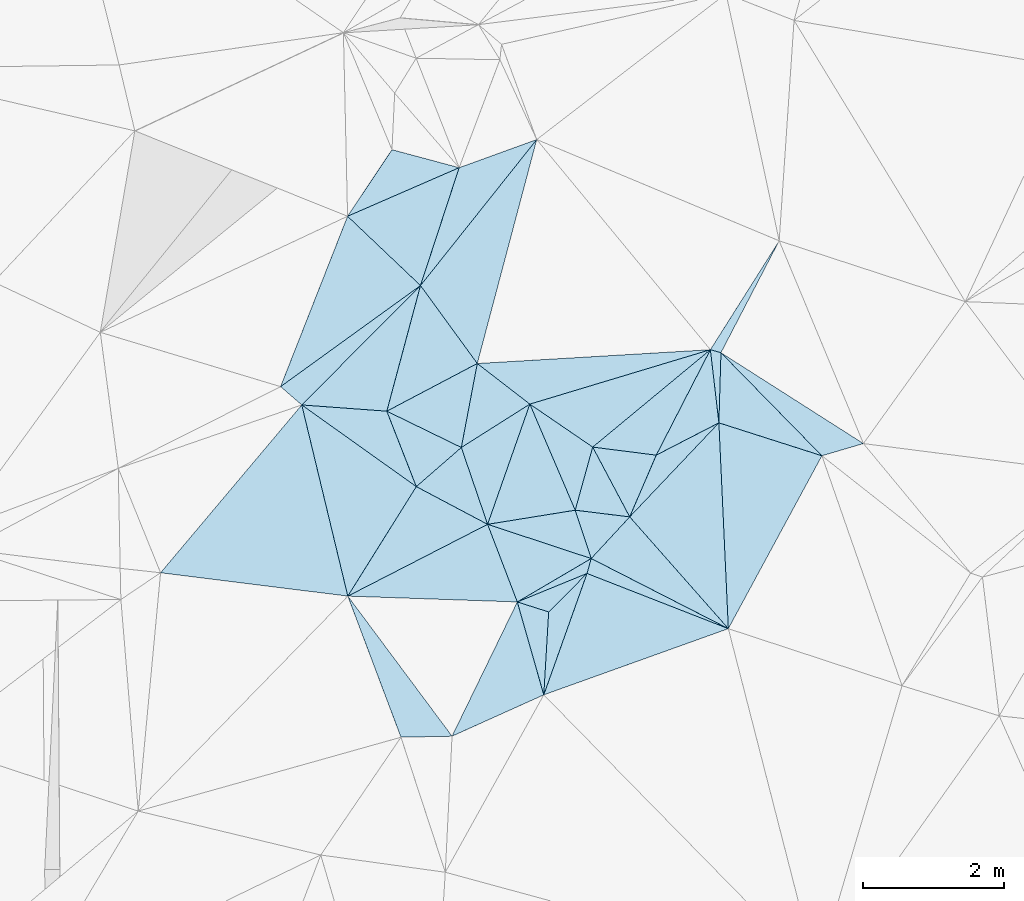
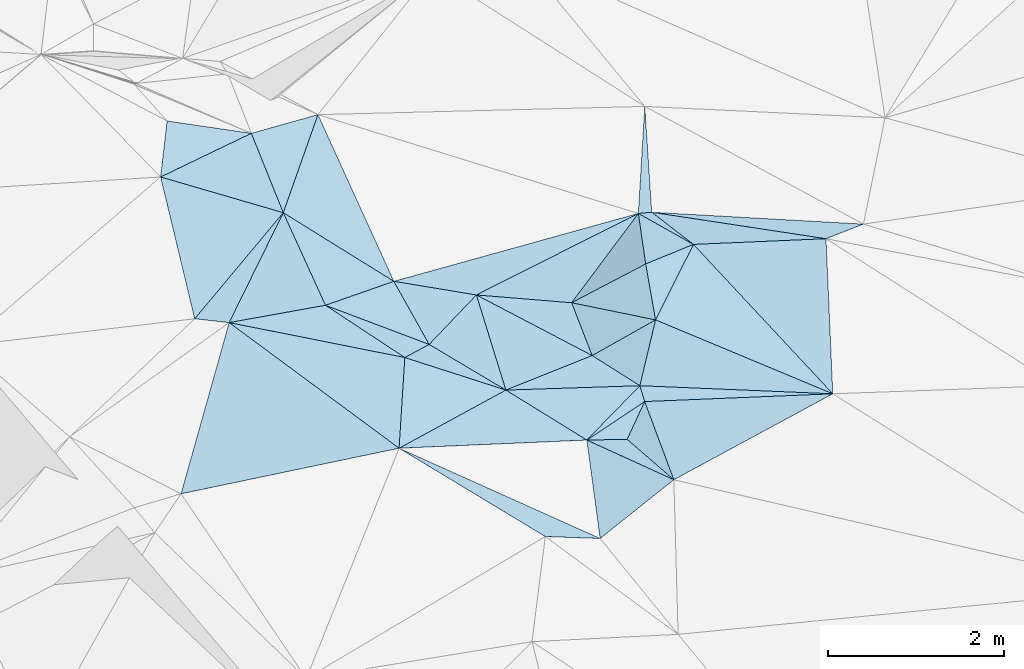
# One storey, part 156 of 275: 45 plates.
"""IFC2X3 building model written with IfcOpenShell, lengths in millimetres."""

from ifc_helpers import new_model, si_unit, frame, origin_with_axes, place, context, subcontext, project, spatial, polyline, outline, extrude, material, type_object, element, save


model = new_model("IFC2X3")

# Units and contexts
model_context = context("Model", 3, precision=1e-05, world=origin_with_axes())
body_context = subcontext(model_context, "Body", "Model", "MODEL_VIEW")
ifc_project = project(units=[si_unit("LENGTHUNIT", "METRE", prefix="MILLI"), si_unit("AREAUNIT", "SQUARE_METRE"), si_unit("VOLUMEUNIT", "CUBIC_METRE"), si_unit("MASSUNIT", "GRAM", prefix="KILO"), si_unit("TIMEUNIT", "SECOND"), si_unit("PLANEANGLEUNIT", "RADIAN"), si_unit("SOLIDANGLEUNIT", "STERADIAN"), si_unit("THERMODYNAMICTEMPERATUREUNIT", "DEGREE_CELSIUS"), si_unit("LUMINOUSINTENSITYUNIT", "LUMEN")], contexts=[model_context])

# Site, building, storey
site_placement = place(None, origin_with_axes())
site = spatial("IfcSite", under=ifc_project, at=site_placement, CompositionType="ELEMENT")
building_placement = place(site_placement, origin_with_axes())
building = spatial("IfcBuilding", under=site, at=building_placement, Name="Undefined", CompositionType="ELEMENT")
storey_placement = place(building_placement, origin_with_axes())
storey = spatial("IfcBuildingStorey", under=building, at=storey_placement, Name="Undefined", CompositionType="ELEMENT", Elevation=0.0)

# Plates
ifc_material = material()
plate_type_1 = type_object("IfcPlateType", PredefinedType="NOTDEFINED")
plate_1_placement = place(storey_placement, frame((-36324.0529379722, 116391.682802069, 45879.5042539643), z_axis=(-0.0657141059388461, 0.112214905189025, -0.991508684447129), x_axis=(-0.0455778950817998, 0.992281826204322, 0.115323167076387)))
element("IfcPlate", 1, at=plate_1_placement, inside=storey, type_object=plate_type_1, material=ifc_material, Name="00", context=body_context, shape_type="SweptSolid", body=[
    extrude(outline(polyline([(0.0, 0.0), (2948.23681640625, -1.5352270565927e-09), (2399.90893554688, 1443.86169433594), (0.0, 0.0)])), frame((-8.85201319254618e-08, 2.18876761149539e-07, -0.5000001331573), z_axis=(0.0, 0.0, 1.0), x_axis=(1.0, 0.0, 0.0)), (0.0, 0.0, 1.0), 1.0),
])
plate_type_2 = type_object("IfcPlateType", PredefinedType="NOTDEFINED")
plate_2_placement = place(storey_placement, frame((-36429.0984635988, 120314.041744215, 46049.5124536224), z_axis=(-0.151597191690274, -0.161799097690605, -0.975109913526741), x_axis=(0.69970543931873, -0.714364877257852, 0.00975296509565245)))
element("IfcPlate", 2, at=plate_2_placement, inside=storey, type_object=plate_type_2, material=ifc_material, Name="00", context=body_context, shape_type="SweptSolid", body=[
    extrude(outline(polyline([(0.0, 0.0), (2050.65844726563, 3.08500602841377e-09), (693.338256835938, 736.940979003906), (0.0, 0.0)])), frame((-8.85201319254618e-08, 2.18876761149539e-07, -0.5000001331573), z_axis=(0.0, 0.0, 1.0), x_axis=(1.0, 0.0, 0.0)), (0.0, 0.0, 1.0), 1.0),
])
plate_type_3 = type_object("IfcPlateType", PredefinedType="NOTDEFINED")
plate_3_placement = place(storey_placement, frame((-36323.9551393121, 116391.839074783, 45879.552046232), z_axis=(0.129888435724304, 0.424791822155536, -0.895924607372112), x_axis=(-0.8870264109226, 0.453553524861327, 0.0864485188516094)))
element("IfcPlate", 3, at=plate_3_placement, inside=storey, type_object=plate_type_3, material=ifc_material, Name="00", context=body_context, shape_type="SweptSolid", body=[
    extrude(outline(polyline([(0.0, 0.0), (2197.83984375, -7.27595761418343e-11), (2011.83898925781, 863.135986328125), (0.0, 0.0)])), frame((-8.85201319254618e-08, 2.18876761149539e-07, -0.5000001331573), z_axis=(0.0, 0.0, 1.0), x_axis=(1.0, 0.0, 0.0)), (0.0, 0.0, 1.0), 1.0),
])
plate_type_4 = type_object("IfcPlateType", PredefinedType="NOTDEFINED")
plate_4_placement = place(storey_placement, frame((-38273.5949539669, 117388.528462846, 46069.5051526097), z_axis=(-0.0654767039366603, 0.127412382830634, -0.989686256317128), x_axis=(-0.86204342690481, -0.506767930713714, -0.00820941717492133)))
element("IfcPlate", 4, at=plate_4_placement, inside=storey, type_object=plate_type_4, material=ifc_material, Name="00", context=body_context, shape_type="SweptSolid", body=[
    extrude(outline(polyline([(0.0, 0.0), (1218.11328125, 3.27418092638254e-09), (1021.49774169922, 1177.38793945313), (0.0, 0.0)])), frame((-8.85201319254618e-08, 2.18876761149539e-07, -0.5000001331573), z_axis=(0.0, 0.0, 1.0), x_axis=(1.0, 0.0, 0.0)), (0.0, 0.0, 1.0), 1.0),
])
plate_type_5 = type_object("IfcPlateType", PredefinedType="NOTDEFINED")
plate_5_placement = place(storey_placement, frame((-39145.5367006344, 119583.364981642, 46299.5028179796), z_axis=(-0.076772100434279, 0.0728998339284036, -0.994380037414328), x_axis=(-0.844680873789874, -0.534637469978889, 0.0260191688596494)))
element("IfcPlate", 5, at=plate_5_placement, inside=storey, type_object=plate_type_5, material=ifc_material, Name="00", context=body_context, shape_type="SweptSolid", body=[
    extrude(outline(polyline([(0.0, 0.0), (1152.99609375, 5.96628524363041e-09), (325.152893066406, 892.006530761719), (0.0, 0.0)])), frame((-8.85201319254618e-08, 2.18876761149539e-07, -0.5000001331573), z_axis=(0.0, 0.0, 1.0), x_axis=(1.0, 0.0, 0.0)), (0.0, 0.0, 1.0), 1.0),
])
plate_type_6 = type_object("IfcPlateType", PredefinedType="NOTDEFINED")
plate_6_placement = place(storey_placement, frame((-40759.204701639, 118410.805984725, 46709.5090750769), z_axis=(-0.0934703041772777, 0.164942871516741, -0.981864120626077), x_axis=(-0.80211392311818, 0.571742619947235, 0.172405425888613)))
element("IfcPlate", 6, at=plate_6_placement, inside=storey, type_object=plate_type_6, material=ifc_material, Name="00", context=body_context, shape_type="SweptSolid", body=[
    extrude(outline(polyline([(0.0, 0.0), (2030.09851074219, 8.71659722179174e-09), (987.144226074219, 631.621948242188), (0.0, 0.0)])), frame((-8.85201319254618e-08, 2.18876761149539e-07, -0.5000001331573), z_axis=(0.0, 0.0, 1.0), x_axis=(1.0, 0.0, 0.0)), (0.0, 0.0, 1.0), 1.0),
])
plate_type_7 = type_object("IfcPlateType", PredefinedType="NOTDEFINED")
plate_7_placement = place(storey_placement, frame((-37725.9721906899, 117980.358393706, 46429.5300184706), z_axis=(0.341076844012425, 0.0103039036585186, -0.939978944470524), x_axis=(-0.934247274577722, 0.114509746901739, -0.337741836035453)))
element("IfcPlate", 7, at=plate_7_placement, inside=storey, type_object=plate_type_7, material=ifc_material, Name="00", context=body_context, shape_type="SweptSolid", body=[
    extrude(outline(polyline([(0.0, 0.0), (829.035583496094, -2.91038304567337e-09), (665.833923339844, 921.88134765625), (0.0, 0.0)])), frame((-8.85201319254618e-08, 2.18876761149539e-07, -0.5000001331573), z_axis=(0.0, 0.0, 1.0), x_axis=(1.0, 0.0, 0.0)), (0.0, 0.0, 1.0), 1.0),
])
plate_type_8 = type_object("IfcPlateType", PredefinedType="NOTDEFINED")
plate_8_placement = place(storey_placement, frame((-42387.6061212349, 119571.456580096, 47059.5076671303), z_axis=(-0.155734536558891, 0.0784396159122018, -0.984679633575476), x_axis=(0.802113923119723, -0.571742619944116, -0.172405425891775)))
element("IfcPlate", 8, at=plate_8_placement, inside=storey, type_object=plate_type_8, material=ifc_material, Name="00", context=body_context, shape_type="SweptSolid", body=[
    extrude(outline(polyline([(0.0, 0.0), (2030.09851074219, 8.71659722179174e-09), (2133.88647460938, 1833.41979980469), (0.0, 0.0)])), frame((-8.85201319254618e-08, 2.18876761149539e-07, -0.5000001331573), z_axis=(0.0, 0.0, 1.0), x_axis=(1.0, 0.0, 0.0)), (0.0, 0.0, 1.0), 1.0),
])
plate_type_9 = type_object("IfcPlateType", PredefinedType="NOTDEFINED")
plate_9_placement = place(storey_placement, frame((-38947.4173455536, 115450.393857707, 46179.5127213931), z_axis=(0.158721121150064, -0.158165253935802, -0.974572397592036), x_axis=(0.0580453039130361, 0.986872741990859, -0.15070810797395)))
element("IfcPlate", 9, at=plate_9_placement, inside=storey, type_object=plate_type_9, material=ifc_material, Name="00", context=body_context, shape_type="SweptSolid", body=[
    extrude(outline(polyline([(0.0, 0.0), (1194.36169433594, -2.4156179279089e-09), (1766.0478515625, 519.591186523438), (0.0, 0.0)])), frame((-8.85201319254618e-08, 2.18876761149539e-07, -0.5000001331573), z_axis=(0.0, 0.0, 1.0), x_axis=(1.0, 0.0, 0.0)), (0.0, 0.0, 1.0), 1.0),
])
plate_type_10 = type_object("IfcPlateType", PredefinedType="NOTDEFINED")
plate_10_placement = place(storey_placement, frame((-41736.616804398, 122253.710428614, 47219.5137133098), z_axis=(-0.232209459996163, 0.0123116298215459, -0.972587883154745), x_axis=(0.896651908904178, 0.390225496001161, -0.209139705768994)))
element("IfcPlate", 10, at=plate_10_placement, inside=storey, type_object=plate_type_10, material=ifc_material, Name="00", context=body_context, shape_type="SweptSolid", body=[
    extrude(outline(polyline([(0.0, 0.0), (1769.15234375, -1.03318598121405e-08), (599.665710449219, 1323.9716796875), (0.0, 0.0)])), frame((-8.85201319254618e-08, 2.18876761149539e-07, -0.5000001331573), z_axis=(0.0, 0.0, 1.0), x_axis=(1.0, 0.0, 0.0)), (0.0, 0.0, 1.0), 1.0),
])
plate_type_11 = type_object("IfcPlateType", PredefinedType="NOTDEFINED")
plate_11_placement = place(storey_placement, frame((-41733.0546176606, 116854.171871205, 46739.5388444543), z_axis=(-0.335343131033077, 0.191991787147957, -0.922325397100539), x_axis=(0.530250922979917, 0.847683355144033, -0.0163367099105726)))
element("IfcPlate", 11, at=plate_11_placement, inside=storey, type_object=plate_type_11, material=ifc_material, Name="00", context=body_context, shape_type="SweptSolid", body=[
    extrude(outline(polyline([(0.0, 0.0), (1836.35510253906, 7.75617081671953e-09), (1927.07824707031, 1239.46325683594), (0.0, 0.0)])), frame((-8.85201319254618e-08, 2.18876761149539e-07, -0.5000001331573), z_axis=(0.0, 0.0, 1.0), x_axis=(1.0, 0.0, 0.0)), (0.0, 0.0, 1.0), 1.0),
])
plate_type_12 = type_object("IfcPlateType", PredefinedType="NOTDEFINED")
plate_12_placement = place(storey_placement, frame((-41732.8986607856, 116854.131551355, 46739.503254641), z_axis=(-0.0234306380726592, 0.111352527860178, -0.993504715509019), x_axis=(-0.991613315912719, 0.123753751896309, 0.0372564168455421)))
element("IfcPlate", 12, at=plate_12_placement, inside=storey, type_object=plate_type_12, material=ifc_material, Name="00", context=body_context, shape_type="SweptSolid", body=[
    extrude(outline(polyline([(0.0, 0.0), (2684.10131835938, -4.17639967054129e-09), (997.354309082031, 2630.62426757813), (0.0, 0.0)])), frame((-8.85201319254618e-08, 2.18876761149539e-07, -0.5000001331573), z_axis=(0.0, 0.0, 1.0), x_axis=(1.0, 0.0, 0.0)), (0.0, 0.0, 1.0), 1.0),
])
plate_type_13 = type_object("IfcPlateType", PredefinedType="NOTDEFINED")
plate_13_placement = place(storey_placement, frame((-38273.5323569123, 117388.613631736, 46069.5236252665), z_axis=(0.0594345141804961, 0.297837132491507, -0.95276470391874), x_axis=(0.887026410928532, -0.453553524848595, -0.0864485188575365)))
element("IfcPlate", 13, at=plate_13_placement, inside=storey, type_object=plate_type_13, material=ifc_material, Name="00", context=body_context, shape_type="SweptSolid", body=[
    extrude(outline(polyline([(0.0, 0.0), (2197.83984375, -7.27595761418343e-11), (49.6396484375, 225.689849853516), (0.0, 0.0)])), frame((-8.85201319254618e-08, 2.18876761149539e-07, -0.5000001331573), z_axis=(0.0, 0.0, 1.0), x_axis=(1.0, 0.0, 0.0)), (0.0, 0.0, 1.0), 1.0),
])
plate_type_14 = type_object("IfcPlateType", PredefinedType="NOTDEFINED")
plate_14_placement = place(storey_placement, frame((-38332.9192508135, 117176.423800452, 45999.5051337343), z_axis=(-0.101171922961455, 0.100817602451982, -0.989747469327462), x_axis=(-0.705865321217639, -0.708346065353877, -1.17079758962413e-10)))
element("IfcPlate", 14, at=plate_14_placement, inside=storey, type_object=plate_type_14, material=ifc_material, Name="00", context=body_context, shape_type="SweptSolid", body=[
    extrude(outline(polyline([(0.0, 0.0), (772.5283203125, 3.59432306140661e-09), (986.37158203125, 420.084564208984), (0.0, 0.0)])), frame((-8.85201319254618e-08, 2.18876761149539e-07, -0.5000001331573), z_axis=(0.0, 0.0, 1.0), x_axis=(1.0, 0.0, 0.0)), (0.0, 0.0, 1.0), 1.0),
])
plate_type_15 = type_object("IfcPlateType", PredefinedType="NOTDEFINED")
plate_15_placement = place(storey_placement, frame((-37726.3708693678, 117980.503858631, 46429.5813532309), z_axis=(-0.456285821586323, 0.301192509938871, -0.837308975812404), x_axis=(0.392488447888442, 0.912614967042225, 0.114397291072119)))
element("IfcPlate", 15, at=plate_15_placement, inside=storey, type_object=plate_type_15, material=ifc_material, Name="00", context=body_context, shape_type="SweptSolid", body=[
    extrude(outline(polyline([(0.0, 0.0), (961.561218261719, -4.75847627967596e-09), (1693.49584960938, 755.163330078125), (0.0, 0.0)])), frame((-8.85201319254618e-08, 2.18876761149539e-07, -0.5000001331573), z_axis=(0.0, 0.0, 1.0), x_axis=(1.0, 0.0, 0.0)), (0.0, 0.0, 1.0), 1.0),
])
plate_type_16 = type_object("IfcPlateType", PredefinedType="NOTDEFINED")
plate_16_placement = place(storey_placement, frame((-37725.9649845596, 117980.464893993, 46429.5461948159), z_axis=(0.355483136529193, 0.223263414473924, -0.907626127544163), x_axis=(-0.619989346981595, -0.67035372217256, -0.407724290175028)))
element("IfcPlate", 16, at=plate_16_placement, inside=storey, type_object=plate_type_16, material=ifc_material, Name="00", context=body_context, shape_type="SweptSolid", body=[
    extrude(outline(polyline([(0.0, 0.0), (882.949584960938, 1.97906047105789e-09), (530.721130371094, 636.894897460938), (0.0, 0.0)])), frame((-8.85201319254618e-08, 2.18876761149539e-07, -0.5000001331573), z_axis=(0.0, 0.0, 1.0), x_axis=(1.0, 0.0, 0.0)), (0.0, 0.0, 1.0), 1.0),
])
plate_type_17 = type_object("IfcPlateType", PredefinedType="NOTDEFINED")
plate_17_placement = place(storey_placement, frame((-40759.4076229765, 118410.714757177, 46709.5668853696), z_axis=(-0.49931410258358, -0.0175101173520629, -0.866244089591076), x_axis=(-0.357758413971271, 0.914750189601731, 0.187725884886335)))
element("IfcPlate", 17, at=plate_17_placement, inside=storey, type_object=plate_type_17, material=ifc_material, Name="00", context=body_context, shape_type="SweptSolid", body=[
    extrude(outline(polyline([(0.0, 0.0), (1171.92150878906, 3.85261955671012e-09), (208.54638671875, 905.267028808594), (0.0, 0.0)])), frame((-8.85201319254618e-08, 2.18876761149539e-07, -0.5000001331573), z_axis=(0.0, 0.0, 1.0), x_axis=(1.0, 0.0, 0.0)), (0.0, 0.0, 1.0), 1.0),
])
plate_type_18 = type_object("IfcPlateType", PredefinedType="NOTDEFINED")
plate_18_placement = place(storey_placement, frame((-42387.5419417405, 119571.401540696, 47059.500445104), z_axis=(-0.0273789872981697, -0.0316380866786816, -0.999124327862073), x_axis=(-0.756170173076635, 0.654375021947852, -1.00918765531188e-10)))
element("IfcPlate", 18, at=plate_18_placement, inside=storey, type_object=plate_type_18, material=ifc_material, Name="00", context=body_context, shape_type="SweptSolid", body=[
    extrude(outline(polyline([(0.0, 0.0), (398.120574951172, -4.36557456851006e-10), (-165.527740478516, 2390.06298828125), (0.0, 0.0)])), frame((-8.85201319254618e-08, 2.18876761149539e-07, -0.5000001331573), z_axis=(0.0, 0.0, 1.0), x_axis=(1.0, 0.0, 0.0)), (0.0, 0.0, 1.0), 1.0),
])
plate_type_19 = type_object("IfcPlateType", PredefinedType="NOTDEFINED")
plate_19_placement = place(storey_placement, frame((-38252.0239744321, 118972.360057638, 46249.5237539641), z_axis=(0.304298515927854, -0.0114718237455573, -0.952507643257552), x_axis=(0.945293004006957, -0.119781322924237, 0.303436272146265)))
element("IfcPlate", 19, at=plate_19_placement, inside=storey, type_object=plate_type_19, material=ifc_material, Name="00", context=body_context, shape_type="SweptSolid", body=[
    extrude(outline(polyline([(0.0, 0.0), (955.719604492188, -2.38651409745216e-09), (670.698791503906, 918.348022460938), (0.0, 0.0)])), frame((-8.85201319254618e-08, 2.18876761149539e-07, -0.5000001331573), z_axis=(0.0, 0.0, 1.0), x_axis=(1.0, 0.0, 0.0)), (0.0, 0.0, 1.0), 1.0),
])
plate_type_20 = type_object("IfcPlateType", PredefinedType="NOTDEFINED")
plate_20_placement = place(storey_placement, frame((-38252.2169731261, 118972.346818329, 46249.5020405172), z_axis=(-0.0816981528576194, -0.0379500336559299, -0.995934338581197), x_axis=(-0.824538746998025, 0.563920224877398, 0.0461501318866018)))
element("IfcPlate", 20, at=plate_20_placement, inside=storey, type_object=plate_type_20, material=ifc_material, Name="00", context=body_context, shape_type="SweptSolid", body=[
    extrude(outline(polyline([(0.0, 0.0), (1083.42053222656, 4.67116478830576e-09), (-607.335754394531, 2093.66748046875), (0.0, 0.0)])), frame((-8.85201319254618e-08, 2.18876761149539e-07, -0.5000001331573), z_axis=(0.0, 0.0, 1.0), x_axis=(1.0, 0.0, 0.0)), (0.0, 0.0, 1.0), 1.0),
])
plate_type_21 = type_object("IfcPlateType", PredefinedType="NOTDEFINED")
plate_21_placement = place(storey_placement, frame((-36458.5263740201, 119317.158155498, 46219.5202780725), z_axis=(-0.263737456425876, 0.0993944994701845, -0.959459893665744), x_axis=(0.0455778951207019, -0.992281826207702, -0.115323167031932)))
element("IfcPlate", 21, at=plate_21_placement, inside=storey, type_object=plate_type_21, material=ifc_material, Name="00", context=body_context, shape_type="SweptSolid", body=[
    extrude(outline(polyline([(0.0, 0.0), (2948.23681640625, -1.5352270565927e-09), (1244.43872070313, 1374.6171875), (0.0, 0.0)])), frame((-8.85201319254618e-08, 2.18876761149539e-07, -0.5000001331573), z_axis=(0.0, 0.0, 1.0), x_axis=(1.0, 0.0, 0.0)), (0.0, 0.0, 1.0), 1.0),
])
plate_type_22 = type_object("IfcPlateType", PredefinedType="NOTDEFINED")
plate_22_placement = place(storey_placement, frame((-36579.0933652959, 120356.860639697, 46059.5574872667), z_axis=(0.233032065081466, -0.402985599877869, -0.885041616498875), x_axis=(-0.43918748286532, -0.855609688858337, 0.273946007866813)))
element("IfcPlate", 22, at=plate_22_placement, inside=storey, type_object=plate_type_22, material=ifc_material, Name="00", context=body_context, shape_type="SweptSolid", body=[
    extrude(outline(polyline([(0.0, 0.0), (1752.17004394531, 6.97764335200191e-09), (1971.55517578125, 930.198974609375), (0.0, 0.0)])), frame((-8.85201319254618e-08, 2.18876761149539e-07, -0.5000001331573), z_axis=(0.0, 0.0, 1.0), x_axis=(1.0, 0.0, 0.0)), (0.0, 0.0, 1.0), 1.0),
])
plate_type_23 = type_object("IfcPlateType", PredefinedType="NOTDEFINED")
plate_23_placement = place(storey_placement, frame((-40699.7850006137, 121268.834031733, 46959.503193417), z_axis=(-0.103572487222844, 0.0444483051282737, -0.993628244396111), x_axis=(-0.258841866871468, -0.96578348388819, -0.0162219050448023)))
element("IfcPlate", 23, at=plate_23_placement, inside=storey, type_object=plate_type_23, material=ifc_material, Name="00", context=body_context, shape_type="SweptSolid", body=[
    extrude(outline(polyline([(0.0, 0.0), (1849.35119628906, -5.23868948221207e-10), (2074.5654296875, 1198.3232421875), (0.0, 0.0)])), frame((-8.85201319254618e-08, 2.18876761149539e-07, -0.5000001331573), z_axis=(0.0, 0.0, 1.0), x_axis=(1.0, 0.0, 0.0)), (0.0, 0.0, 1.0), 1.0),
])
plate_type_24 = type_object("IfcPlateType", PredefinedType="NOTDEFINED")
plate_24_placement = place(storey_placement, frame((-40119.6417972567, 118966.855558215, 46329.5575433439), z_axis=(-0.459465233072403, -0.0761131166696994, -0.884928524271055), x_axis=(0.322383999010539, -0.942666307709149, -0.086306369938569)))
element("IfcPlate", 24, at=plate_24_placement, inside=storey, type_object=plate_type_24, material=ifc_material, Name="00", context=body_context, shape_type="SweptSolid", body=[
    extrude(outline(polyline([(0.0, 0.0), (1158.66296386719, -7.14862835593522e-09), (285.242553710938, 884.102172851563), (0.0, 0.0)])), frame((-8.85201319254618e-08, 2.18876761149539e-07, -0.5000001331573), z_axis=(0.0, 0.0, 1.0), x_axis=(1.0, 0.0, 0.0)), (0.0, 0.0, 1.0), 1.0),
])
plate_type_25 = type_object("IfcPlateType", PredefinedType="NOTDEFINED")
plate_25_placement = place(storey_placement, frame((-39892.8955776665, 120160.565494527, 46399.5555683677), z_axis=(-0.437715405781065, 0.135276885346624, -0.888878725042305), x_axis=(-0.186312372865134, -0.98080534483914, -0.0575202160317553)))
element("IfcPlate", 25, at=plate_25_placement, inside=storey, type_object=plate_type_25, material=ifc_material, Name="00", context=body_context, shape_type="SweptSolid", body=[
    extrude(outline(polyline([(0.0, 0.0), (1216.96337890625, 5.42786438018084e-09), (873.814270019531, 1276.6552734375), (0.0, 0.0)])), frame((-8.85201319254618e-08, 2.18876761149539e-07, -0.5000001331573), z_axis=(0.0, 0.0, 1.0), x_axis=(1.0, 0.0, 0.0)), (0.0, 0.0, 1.0), 1.0),
])
plate_type_26 = type_object("IfcPlateType", PredefinedType="NOTDEFINED")
plate_26_placement = place(storey_placement, frame((-39892.8922249766, 120160.566259175, 46399.5540493067), z_axis=(-0.431008310351895, 0.136807232346122, -0.891916822122668), x_axis=(-0.544947817256938, 0.748365539120235, 0.378128148018869)))
element("IfcPlate", 26, at=plate_26_placement, inside=storey, type_object=plate_type_26, material=ifc_material, Name="00", context=body_context, shape_type="SweptSolid", body=[
    extrude(outline(polyline([(0.0, 0.0), (1480.97937011719, -1.36788003146648e-09), (1952.22155761719, 2654.00268554688), (0.0, 0.0)])), frame((-8.85201319254618e-08, 2.18876761149539e-07, -0.5000001331573), z_axis=(0.0, 0.0, 1.0), x_axis=(1.0, 0.0, 0.0)), (0.0, 0.0, 1.0), 1.0),
])
plate_type_27 = type_object("IfcPlateType", PredefinedType="NOTDEFINED")
plate_27_placement = place(storey_placement, frame((-40699.8998458039, 121268.835553816, 46959.5291887237), z_axis=(-0.333260335317783, 0.0474921996832551, -0.941637955837128), x_axis=(0.311089438069843, 0.948338495490941, -0.0622692499663267)))
element("IfcPlate", 27, at=plate_27_placement, inside=storey, type_object=plate_type_27, material=ifc_material, Name="00", context=body_context, shape_type="SweptSolid", body=[
    extrude(outline(polyline([(0.0, 0.0), (1766.52197265625, -4.94765117764473e-09), (2511.77172851563, 978.163024902344), (0.0, 0.0)])), frame((-8.85201319254618e-08, 2.18876761149539e-07, -0.5000001331573), z_axis=(0.0, 0.0, 1.0), x_axis=(1.0, 0.0, 0.0)), (0.0, 0.0, 1.0), 1.0),
])
plate_28_placement = place(storey_placement, frame((-41736.6488489174, 122253.793228796, 47219.5308160857), z_axis=(-0.296294488101892, 0.177896931092957, -0.938382788753154), x_axis=(0.555011880882439, 0.831656610008268, -0.0175811009010604)))
element("IfcPlate", 28, at=plate_28_placement, inside=storey, type_object=plate_type_27, material=ifc_material, Name="00", context=body_context, shape_type="SweptSolid", body=[
    extrude(outline(polyline([(0.0, 0.0), (1137.58520507813, 3.49245965480804e-09), (1461.07739257813, 997.573425292969), (0.0, 0.0)])), frame((-8.85201319254618e-08, 2.18876761149539e-07, -0.5000001331573), z_axis=(0.0, 0.0, 1.0), x_axis=(1.0, 0.0, 0.0)), (0.0, 0.0, 1.0), 1.0),
])
plate_type_28 = type_object("IfcPlateType", PredefinedType="NOTDEFINED")
plate_29_placement = place(storey_placement, frame((-40699.9514235218, 121268.877763637, 46959.5549957565), z_axis=(-0.436414373422252, 0.131913813528752, -0.890023168502239), x_axis=(0.544947817260098, -0.748365539119888, -0.378128148015001)))
element("IfcPlate", 29, at=plate_29_placement, inside=storey, type_object=plate_type_28, material=ifc_material, Name="00", context=body_context, shape_type="SweptSolid", body=[
    extrude(outline(polyline([(0.0, 0.0), (1480.97937011719, -1.36788003146648e-09), (1087.11840820313, 1496.08605957031), (0.0, 0.0)])), frame((-8.85201319254618e-08, 2.18876761149539e-07, -0.5000001331573), z_axis=(0.0, 0.0, 1.0), x_axis=(1.0, 0.0, 0.0)), (0.0, 0.0, 1.0), 1.0),
])
plate_type_29 = type_object("IfcPlateType", PredefinedType="NOTDEFINED")
plate_30_placement = place(storey_placement, frame((-39323.7293218354, 116771.342595337, 46059.5439991206), z_axis=(-0.201369734444828, 0.357316581488959, -0.912017045149192), x_axis=(0.862043427200345, 0.506767930210608, 0.00820941719858111)))
element("IfcPlate", 30, at=plate_30_placement, inside=storey, type_object=plate_type_29, material=ifc_material, Name="00", context=body_context, shape_type="SweptSolid", body=[
    extrude(outline(polyline([(0.0, 0.0), (1218.11328125, 3.27418092638254e-09), (1058.93273925781, 167.515777587891), (0.0, 0.0)])), frame((-8.85201319254618e-08, 2.18876761149539e-07, -0.5000001331573), z_axis=(0.0, 0.0, 1.0), x_axis=(1.0, 0.0, 0.0)), (0.0, 0.0, 1.0), 1.0),
])
plate_type_30 = type_object("IfcPlateType", PredefinedType="NOTDEFINED")
plate_31_placement = place(storey_placement, frame((-39745.9139537959, 117874.694143284, 46229.502429889), z_axis=(-0.0726067434133644, 0.0662811769632596, -0.995155800059102), x_axis=(-0.322383999000975, 0.942666307709821, 0.0863063699669484)))
element("IfcPlate", 31, at=plate_31_placement, inside=storey, type_object=plate_type_30, material=ifc_material, Name="00", context=body_context, shape_type="SweptSolid", body=[
    extrude(outline(polyline([(0.0, 0.0), (1158.66296386719, -7.14862835593522e-09), (1423.19201660156, 1122.24084472656), (0.0, 0.0)])), frame((-8.85201319254618e-08, 2.18876761149539e-07, -0.5000001331573), z_axis=(0.0, 0.0, 1.0), x_axis=(1.0, 0.0, 0.0)), (0.0, 0.0, 1.0), 1.0),
])
plate_type_31 = type_object("IfcPlateType", PredefinedType="NOTDEFINED")
plate_32_placement = place(storey_placement, frame((-38947.4786376007, 115450.432806075, 46179.5019464749), z_axis=(0.0361364798615999, -0.0802175304165639, -0.996122132389939), x_axis=(-0.911757289053888, -0.410729407100472, -2.08311170008877e-10)))
element("IfcPlate", 32, at=plate_32_placement, inside=storey, type_object=plate_type_31, material=ifc_material, Name="00", context=body_context, shape_type="SweptSolid", body=[
    extrude(outline(polyline([(0.0, 0.0), (1430.03491210938, 1.54250301420689e-09), (-199.505615234375, 1363.92724609375), (0.0, 0.0)])), frame((-8.85201319254618e-08, 2.18876761149539e-07, -0.5000001331573), z_axis=(0.0, 0.0, 1.0), x_axis=(1.0, 0.0, 0.0)), (0.0, 0.0, 1.0), 1.0),
])
plate_type_32 = type_object("IfcPlateType", PredefinedType="NOTDEFINED")
plate_33_placement = place(storey_placement, frame((-42688.6425059809, 119831.996499425, 47059.5080848997), z_axis=(-0.134681666954745, 0.117947786466124, -0.983844077206359), x_axis=(0.365184455001087, 0.928910085167854, 0.0613707381331689)))
element("IfcPlate", 33, at=plate_33_placement, inside=storey, type_object=plate_type_32, material=ifc_material, Name="00", context=body_context, shape_type="SweptSolid", body=[
    extrude(outline(polyline([(0.0, 0.0), (2607.10571289063, -5.2241375669837e-09), (2054.88403320313, 1344.45202636719), (0.0, 0.0)])), frame((-8.85201319254618e-08, 2.18876761149539e-07, -0.5000001331573), z_axis=(0.0, 0.0, 1.0), x_axis=(1.0, 0.0, 0.0)), (0.0, 0.0, 1.0), 1.0),
])
plate_type_33 = type_object("IfcPlateType", PredefinedType="NOTDEFINED")
plate_34_placement = place(storey_placement, frame((-35601.4498834416, 121904.635474867, 46259.5053428028), z_axis=(-0.0248310586466794, 0.143550998476573, -0.989331354685003), x_axis=(-0.458462535018059, -0.881066552194674, -0.116335010158617)))
element("IfcPlate", 34, at=plate_34_placement, inside=storey, type_object=plate_type_33, material=ifc_material, Name="00", context=body_context, shape_type="SweptSolid", body=[
    extrude(outline(polyline([(0.0, 0.0), (1805.13159179688, 5.1368260756135e-09), (1834.99084472656, 153.650314331055), (0.0, 0.0)])), frame((-8.85201319254618e-08, 2.18876761149539e-07, -0.5000001331573), z_axis=(0.0, 0.0, 1.0), x_axis=(1.0, 0.0, 0.0)), (0.0, 0.0, 1.0), 1.0),
])
plate_type_34 = type_object("IfcPlateType", PredefinedType="NOTDEFINED")
plate_35_placement = place(storey_placement, frame((-36429.0919737589, 120314.048074471, 46049.5104832962), z_axis=(-0.138620976853635, -0.149142971111081, -0.979050866372276), x_axis=(0.842555359330098, -0.537306574149637, -0.0374447838785431)))
element("IfcPlate", 35, at=plate_35_placement, inside=storey, type_object=plate_type_34, material=ifc_material, Name="00", context=body_context, shape_type="SweptSolid", body=[
    extrude(outline(polyline([(0.0, 0.0), (2403.5390625, 4.77302819490433e-09), (1995.30773925781, 473.230560302734), (0.0, 0.0)])), frame((-8.85201319254618e-08, 2.18876761149539e-07, -0.5000001331573), z_axis=(0.0, 0.0, 1.0), x_axis=(1.0, 0.0, 0.0)), (0.0, 0.0, 1.0), 1.0),
])
plate_type_35 = type_object("IfcPlateType", PredefinedType="NOTDEFINED")
plate_36_placement = place(storey_placement, frame((-36579.33562471, 120356.974303641, 46059.5241142788), z_axis=(-0.251485889026461, -0.175651596422233, -0.951788508175473), x_axis=(0.114073259078283, -0.981918932560912, 0.151071180049994)))
element("IfcPlate", 36, at=plate_36_placement, inside=storey, type_object=plate_type_35, material=ifc_material, Name="00", context=body_context, shape_type="SweptSolid", body=[
    extrude(outline(polyline([(0.0, 0.0), (1059.10339355469, -6.14090822637081e-09), (1456.79821777344, 973.570129394531), (0.0, 0.0)])), frame((-8.85201319254618e-08, 2.18876761149539e-07, -0.5000001331573), z_axis=(0.0, 0.0, 1.0), x_axis=(1.0, 0.0, 0.0)), (0.0, 0.0, 1.0), 1.0),
])
plate_type_36 = type_object("IfcPlateType", PredefinedType="NOTDEFINED")
plate_37_placement = place(storey_placement, frame((-39145.5356736902, 119583.362031689, 46299.5025324054), z_axis=(-0.0747189930625974, 0.0670149451385268, -0.994950284790045), x_axis=(0.391526600066155, -0.91564839899821, -0.0910765109819857)))
element("IfcPlate", 37, at=plate_37_placement, inside=storey, type_object=plate_type_36, material=ifc_material, Name="00", context=body_context, shape_type="SweptSolid", body=[
    extrude(outline(polyline([(0.0, 0.0), (1646.96691894531, -6.97400537319481e-09), (1335.84948730469, 1224.91064453125), (0.0, 0.0)])), frame((-8.85201319254618e-08, 2.18876761149539e-07, -0.5000001331573), z_axis=(0.0, 0.0, 1.0), x_axis=(1.0, 0.0, 0.0)), (0.0, 0.0, 1.0), 1.0),
])
plate_type_37 = type_object("IfcPlateType", PredefinedType="NOTDEFINED")
plate_38_placement = place(storey_placement, frame((-38273.6012038608, 117388.509579162, 46069.5035663426), z_axis=(-0.078253134885912, 0.0897744328039444, -0.992883174444636), x_axis=(-0.944549187831119, 0.311914333844378, 0.102646383813516)))
element("IfcPlate", 38, at=plate_38_placement, inside=storey, type_object=plate_type_37, material=ifc_material, Name="00", context=body_context, shape_type="SweptSolid", body=[
    extrude(outline(polyline([(0.0, 0.0), (1558.74951171875, 2.60479282587767e-09), (436.952819824219, 582.041442871094), (0.0, 0.0)])), frame((-8.85201319254618e-08, 2.18876761149539e-07, -0.5000001331573), z_axis=(0.0, 0.0, 1.0), x_axis=(1.0, 0.0, 0.0)), (0.0, 0.0, 1.0), 1.0),
])
plate_39_placement = place(storey_placement, frame((-38500.6584966137, 118075.338959026, 46149.5029042072), z_axis=(0.0169410363784273, 0.106134422016767, -0.994207466150598), x_axis=(-0.39152660013638, 0.915648398967212, 0.0910765109917359)))
element("IfcPlate", 39, at=plate_39_placement, inside=storey, type_object=plate_type_37, material=ifc_material, Name="00", context=body_context, shape_type="SweptSolid", body=[
    extrude(outline(polyline([(0.0, 0.0), (1646.96691894531, -6.97400537319481e-09), (733.226623535156, 582.132873535156), (0.0, 0.0)])), frame((-8.85201319254618e-08, 2.18876761149539e-07, -0.5000001331573), z_axis=(0.0, 0.0, 1.0), x_axis=(1.0, 0.0, 0.0)), (0.0, 0.0, 1.0), 1.0),
])
plate_type_38 = type_object("IfcPlateType", PredefinedType="NOTDEFINED")
plate_40_placement = place(storey_placement, frame((-39746.0126134661, 117874.683446378, 46229.5190906375), z_axis=(-0.269927502021225, 0.0448892094320584, -0.961833718752439), x_axis=(0.353733711202399, -0.924440553237148, -0.142415326034715)))
element("IfcPlate", 40, at=plate_40_placement, inside=storey, type_object=plate_type_38, material=ifc_material, Name="00", context=body_context, shape_type="SweptSolid", body=[
    extrude(outline(polyline([(0.0, 0.0), (1193.69177246094, 6.54836185276508e-10), (167.96630859375, 2285.10107421875), (0.0, 0.0)])), frame((-8.85201319254618e-08, 2.18876761149539e-07, -0.5000001331573), z_axis=(0.0, 0.0, 1.0), x_axis=(1.0, 0.0, 0.0)), (0.0, 0.0, 1.0), 1.0),
])
plate_type_39 = type_object("IfcPlateType", PredefinedType="NOTDEFINED")
plate_41_placement = place(storey_placement, frame((-41733.0722732275, 116854.06854437, 46739.5356785722), z_axis=(-0.370651409815257, -0.0146104934732618, -0.928657130421358), x_axis=(0.58234311625197, -0.782576102149429, -0.220116194993808)))
element("IfcPlate", 41, at=plate_41_placement, inside=storey, type_object=plate_type_39, material=ifc_material, Name="00", context=body_context, shape_type="SweptSolid", body=[
    extrude(outline(polyline([(0.0, 0.0), (2544.11083984375, -6.81029632687569e-09), (2069.09228515625, 621.093627929688), (0.0, 0.0)])), frame((-8.85201319254618e-08, 2.18876761149539e-07, -0.5000001331573), z_axis=(0.0, 0.0, 1.0), x_axis=(1.0, 0.0, 0.0)), (0.0, 0.0, 1.0), 1.0),
])
plate_42_placement = place(storey_placement, frame((-36579.2619821966, 120357.080766303, 46059.5030799223), z_axis=(-0.104194501917095, 0.0373093408140878, -0.993856890532167), x_axis=(-0.953615293793849, -0.287514134011061, 0.0891823647720837)))
element("IfcPlate", 42, at=plate_42_placement, inside=storey, type_object=plate_type_39, material=ifc_material, Name="00", context=body_context, shape_type="SweptSolid", body=[
    extrude(outline(polyline([(0.0, 0.0), (2691.11499023438, 6.30097929388285e-09), (3246.60961914063, 769.951721191406), (0.0, 0.0)])), frame((-8.85201319254618e-08, 2.18876761149539e-07, -0.5000001331573), z_axis=(0.0, 0.0, 1.0), x_axis=(1.0, 0.0, 0.0)), (0.0, 0.0, 1.0), 1.0),
])
plate_type_40 = type_object("IfcPlateType", PredefinedType="NOTDEFINED")
plate_43_placement = place(storey_placement, frame((-39323.7163604308, 116771.094672415, 46059.5126602031), z_axis=(-0.175445690946103, -0.138529006397601, -0.974694066830684), x_axis=(0.945008534207464, -0.301259439958058, -0.127285584852397)))
element("IfcPlate", 43, at=plate_43_placement, inside=storey, type_object=plate_type_40, material=ifc_material, Name="00", context=body_context, shape_type="SweptSolid", body=[
    extrude(outline(polyline([(0.0, 0.0), (471.380950927734, -1.33877620100975e-09), (738.044250488281, 1164.21252441406), (0.0, 0.0)])), frame((-8.85201319254618e-08, 2.18876761149539e-07, -0.5000001331573), z_axis=(0.0, 0.0, 1.0), x_axis=(1.0, 0.0, 0.0)), (0.0, 0.0, 1.0), 1.0),
])
plate_type_41 = type_object("IfcPlateType", PredefinedType="NOTDEFINED")
plate_44_placement = place(storey_placement, frame((-38332.9124863448, 117176.33716481, 45999.5032487842), z_axis=(-0.0876346320023292, -0.0724088441055404, -0.993517554232997), x_axis=(0.930012526040716, -0.363304758906959, -0.0555549598408964)))
element("IfcPlate", 44, at=plate_44_placement, inside=storey, type_object=plate_type_41, material=ifc_material, Name="00", context=body_context, shape_type="SweptSolid", body=[
    extrude(outline(polyline([(0.0, 0.0), (2160.02319335938, 3.69618646800518e-09), (45.4161796569824, 1840.33618164063), (0.0, 0.0)])), frame((-8.85201319254618e-08, 2.18876761149539e-07, -0.5000001331573), z_axis=(0.0, 0.0, 1.0), x_axis=(1.0, 0.0, 0.0)), (0.0, 0.0, 1.0), 1.0),
])
plate_type_42 = type_object("IfcPlateType", PredefinedType="NOTDEFINED")
plate_45_placement = place(storey_placement, frame((-36458.4505606102, 119317.026526967, 46219.5099576036), z_axis=(-0.112094159529767, -0.163814039068792, -0.980101964085005), x_axis=(-0.114073259149153, 0.981918932554701, -0.151071180036851)))
element("IfcPlate", 45, at=plate_45_placement, inside=storey, type_object=plate_type_42, material=ifc_material, Name="00", context=body_context, shape_type="SweptSolid", body=[
    extrude(outline(polyline([(0.0, 0.0), (1059.10339355469, -6.14090822637081e-09), (1001.31866455078, 145.467956542969), (0.0, 0.0)])), frame((-8.85201319254618e-08, 2.18876761149539e-07, -0.5000001331573), z_axis=(0.0, 0.0, 1.0), x_axis=(1.0, 0.0, 0.0)), (0.0, 0.0, 1.0), 1.0),
])

save(model, "model.ifc")
